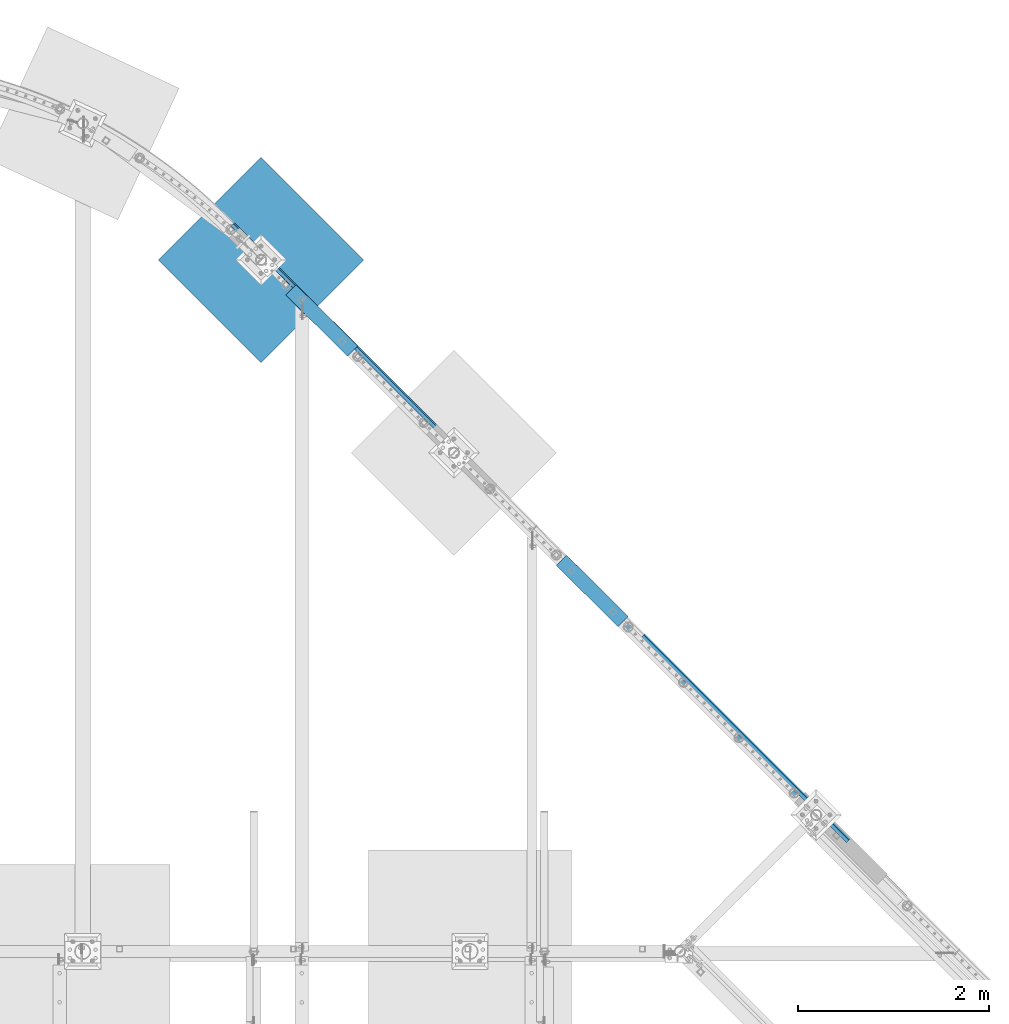
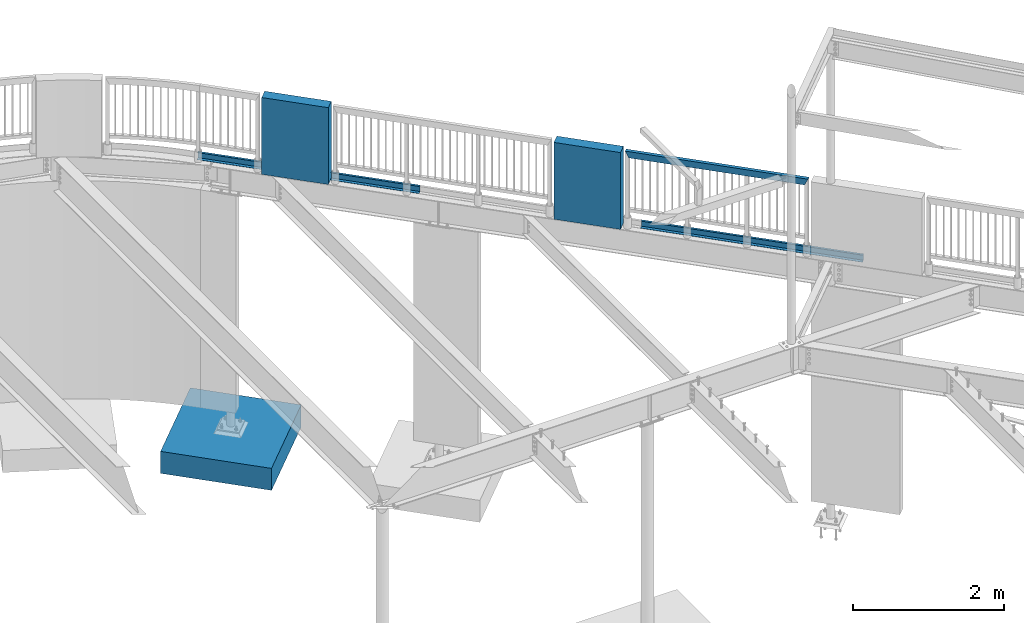
# One storey, part 332 of 975: 6 beams.
"""IFC2X3 building model written with IfcOpenShell, lengths in millimetres."""

from ifc_helpers import new_model, si_unit, frame, origin_with_axes, place, context, subcontext, project, spatial, faceted_brep, material, type_object, element, save


model = new_model("IFC2X3")

# Units and contexts
model_context = context("Model", 3, precision=1e-05, world=origin_with_axes())
body_context = subcontext(model_context, "Body", "Model", "MODEL_VIEW")
ifc_project = project(units=[si_unit("LENGTHUNIT", "METRE", prefix="MILLI"), si_unit("AREAUNIT", "SQUARE_METRE"), si_unit("VOLUMEUNIT", "CUBIC_METRE"), si_unit("MASSUNIT", "GRAM", prefix="KILO"), si_unit("TIMEUNIT", "SECOND"), si_unit("PLANEANGLEUNIT", "RADIAN"), si_unit("SOLIDANGLEUNIT", "STERADIAN"), si_unit("THERMODYNAMICTEMPERATUREUNIT", "DEGREE_CELSIUS"), si_unit("LUMINOUSINTENSITYUNIT", "LUMEN")], contexts=[model_context])

# Site, building, storey
site_placement = place(None, origin_with_axes())
site = spatial("IfcSite", under=ifc_project, at=site_placement, CompositionType="ELEMENT")
building_placement = place(site_placement, origin_with_axes())
building = spatial("IfcBuilding", under=site, at=building_placement, Name="Undefined", CompositionType="ELEMENT")
storey_placement = place(building_placement, origin_with_axes())
storey = spatial("IfcBuildingStorey", under=building, at=storey_placement, Name="Undefined", CompositionType="ELEMENT", Elevation=0.0)

# Beams
ifc_material_1 = material()
beam_type_1 = type_object("IfcBeamType", Name="HSS2X4X.188_TUBES", PredefinedType="NOTDEFINED")
beam_1_placement = place(storey_placement, frame((26325.1887491403, 22309.278796974, 5130.8), z_axis=(0.0, 0.0, 1.0), x_axis=(-0.70707231784675, 0.707141242846735, 0.0)))
element("IfcBeam", 1, at=beam_1_placement, inside=storey, type_object=beam_type_1, material=ifc_material_1, Name="GUARDRAIL", ObjectType="HSS2X4X.188_TUBES", context=body_context, shape_type="Brep", body=[
    faceted_brep([(23.0198915490837, 20.6374999999994, -46.0375000000031), (23.0198915283145, -20.6374999999966, -46.0375000000085), (2440.78465707755, -20.6375000036642, -46.0375000000004), (2440.78465707755, 20.6374999963664, -46.0375000000004), (-23.0198845522937, -20.6374999999985, 46.0375000000058), (2486.82437765429, -20.6375000037369, 46.0375000000004), (-23.0198845315244, 20.6374999999973, 46.0375000000113), (2486.82437765429, 20.6374999962936, 46.0375000000004), (25.4012592797953, 25.399999999999, -50.8000000000029), (-25.4012522574303, 25.3999999999967, 50.800000000012), (2489.2057425117, 25.399999996298, 50.8000000000002), (2438.40329222013, 25.3999999963708, -50.8000000000002), (-25.401252282998, -25.3999999999983, 50.8000000000056), (2489.20574251171, -25.4000000037413, 50.8000000000002), (25.401259254224, -25.399999999996, -50.8000000000102), (2438.40329222013, -25.4000000036685, -50.8000000000002)], [[[0, 1, 2, 3]], [[1, 4, 5, 2]], [[4, 6, 7, 5]], [[6, 0, 3, 7]], [[8, 9, 10, 11]], [[9, 12, 13, 10]], [[12, 14, 15, 13]], [[14, 8, 11, 15]], [[13, 15, 11, 10], [5, 7, 3, 2]], [[14, 12, 9, 8], [6, 4, 1, 0]]]),
])
ifc_material_2 = material(Name="STEEL/A36")
beam_type_2 = type_object("IfcBeamType", PredefinedType="NOTDEFINED")
for number, where, z_axis, x_axis, name in (
    (2, (25797.4580351234, 22864.0102136548, 3938.58749694824), (0.707119123078843, -0.707094439078832, 0.0), (0.707094439078834, 0.707119123078842, 0.0), "DECK_EDGE"),
    (3, (21494.4624658951, 27181.8264166938, 3938.58749694824), (0.708204307106826, -0.706007549106482, 0.0), (0.706007549106482, 0.708204307106825, 0.0), "DECK_EDGE"),
):
    element("IfcBeam", number, at=place(storey_placement, frame(where, z_axis=z_axis, x_axis=x_axis)), inside=storey, type_object=beam_type_2, material=ifc_material_2, Name=name, context=body_context, shape_type="Brep", body=[
        faceted_brep([(1.03318598121405e-09, -1.58750000000009, -1524.00000000109), (-1.04046193882823e-09, -1.58750000000009, 1524.0000000011), (-1.04046193882823e-09, 1.58750000000009, 1524.0000000011), (1.03318598121405e-09, 1.58750000000009, -1524.00000000109), (47.6250001214066, 1.58750000000009, 1524.00000000113), (47.6250001235167, 1.58750000000009, -1524.00000000107), (50.8000001235196, -1.58750000000009, -1524.00000000106), (50.8000001214168, -1.58750000000009, 1524.00000000113), (47.6250001214503, 96.837499999901, 1524.00000000113), (47.625000123473, 96.8374999999951, -1524.00000000106), (50.8000001234759, 104.502628762961, -1524.00000000106), (50.8000001214605, 104.502628762867, 1524.00000000113), (38.6447461584321, 87.8572448731024, 1524.00000000113), (38.6447461604548, 87.8572448731024, -1524.00000000107), (36.3996819826862, 90.102308757891, 1524.00000000112), (36.3996819847016, 90.102308757891, -1524.00000000107)], [[[0, 1, 2, 3]], [[3, 2, 4, 5]], [[1, 0, 6, 7]], [[5, 4, 8, 9]], [[7, 6, 10, 11]], [[9, 8, 12, 13]], [[8, 4, 2, 1, 7, 11, 14, 12]], [[11, 10, 15, 14]], [[10, 6, 0, 3, 5, 9, 13, 15]], [[14, 15, 13, 12]]]),
    ])
ifc_material_3 = material(Name="CONCRETE/5000")
beam_type_3 = type_object("IfcBeamType", PredefinedType="NOTDEFINED")
for number, where, z_axis, x_axis, name in (
    (4, (21044.922177834, 27589.7997587402, 4559.3), (0.0, 0.0, 1.0), (0.707901544041155, -0.706311124041062, 0.0), "LOW WALL"),
    (5, (23882.6976544436, 24752.0569558024, 4559.3), (0.0, 0.0, 1.0), (0.707901544041155, -0.706311124041062, 0.0), "LOW WALL"),
):
    element("IfcBeam", number, at=place(storey_placement, frame(where, z_axis=z_axis, x_axis=x_axis)), inside=storey, type_object=beam_type_3, material=ifc_material_3, Name=name, context=body_context, shape_type="Brep", body=[
        faceted_brep([(1.0550138540566e-10, 76.1999999999316, -622.3), (1.0550138540566e-10, 76.1999999999316, 622.3), (914.399999999998, 76.1999999999998, 622.3), (914.399999999998, 76.1999999999998, -622.3), (-1.01863406598568e-10, -76.1999999999243, 622.3), (914.399999999998, -76.2, 622.3), (-1.01863406598568e-10, -76.1999999999243, -622.3), (914.399999999998, -76.2, -622.3)], [[[0, 1, 2, 3]], [[1, 4, 5, 2]], [[4, 6, 7, 5]], [[6, 0, 3, 7]], [[5, 7, 3, 2]], [[6, 4, 1, 0]]]),
    ])
beam_type_4 = type_object("IfcBeamType", PredefinedType="NOTDEFINED")
beam_2_placement = place(storey_placement, frame((20192.3471327311, 27364.6721327256, -482.6), z_axis=(0.0, 0.0, -1.0), x_axis=(0.707106781186548, 0.707106781186548, 0.0)))
element("IfcBeam", 6, at=beam_2_placement, inside=storey, type_object=beam_type_4, material=ifc_material_3, Name="FOOTING", context=body_context, shape_type="Brep", body=[
    faceted_brep([(4.8748916015029e-10, 762.000000001049, -177.8), (4.8748916015029e-10, 762.000000001049, 177.8), (1524.00000000259, 762.000000000074, 177.8), (1524.00000000259, 762.000000000074, -177.8), (-4.80213202536106e-10, -762.000000001047, 177.8), (1524.00000000162, -762.00000000202, 177.8), (-4.80213202536106e-10, -762.000000001047, -177.8), (1524.00000000162, -762.00000000202, -177.8)], [[[0, 1, 2, 3]], [[1, 4, 5, 2]], [[4, 6, 7, 5]], [[6, 0, 3, 7]], [[5, 7, 3, 2]], [[6, 4, 1, 0]]]),
])

save(model, "model.ifc")
